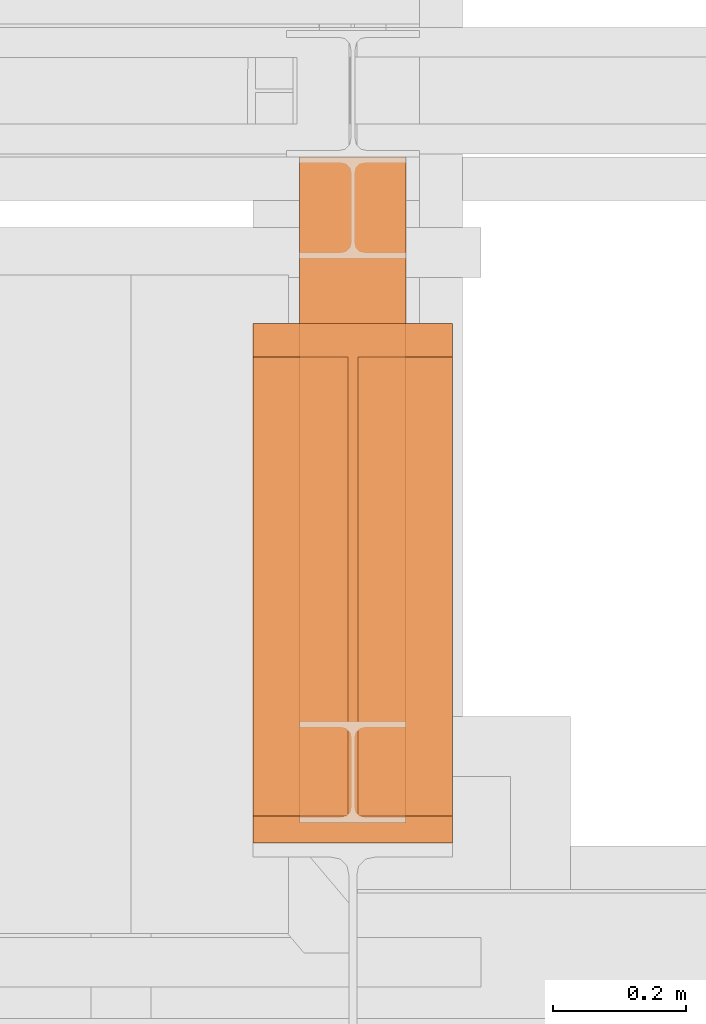
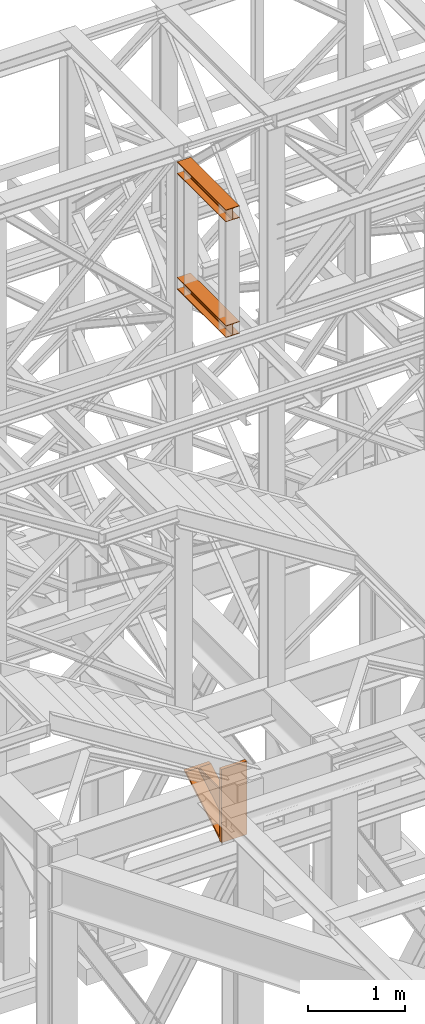
# One storey, part 86 of 208: 3 proxies.
"""IFC2X3 building model written with IfcOpenShell, lengths in millimetres."""

from ifc_helpers import new_model, entity, si_unit, converted_unit, frame, origin, origin_with_axes, place, context, subcontext, project, spatial, faceted_brep, element, save


model = new_model("IFC2X3")

# Units and contexts
model_context = context("Model", 3, precision=1e-05, world=origin())
plan_context = context("Plan", 3, precision=1e-05, world=origin())
body_context = subcontext(model_context, "Body", "Model", "MODEL_VIEW")
ifc_project = project(units=[si_unit("LENGTHUNIT", "METRE", prefix="MILLI"), converted_unit("PLANEANGLEUNIT", "DEGREE", entity("IfcPlaneAngleMeasure", 0.0174532925199433), si_unit("PLANEANGLEUNIT", "RADIAN"), dimensions=[0, 0, 0, 0, 0, 0, 0]), si_unit("AREAUNIT", "SQUARE_METRE"), si_unit("VOLUMEUNIT", "CUBIC_METRE")], contexts=[model_context, plan_context])

# Building, storey
building_placement = place(None, origin())
building = spatial("IfcBuilding", under=ifc_project, at=building_placement, CompositionType="COMPLEX")
storey_placement = place(building_placement, origin_with_axes())
storey = spatial("IfcBuildingStorey", under=building, at=storey_placement, Name="Geschoss", CompositionType="ELEMENT")

# Proxies
proxy_1_placement = place(storey_placement, frame((-1256.745037431798, -17092.57439173937, 4367.230005364415), z_axis=(0.0, 0.0, 1.0), x_axis=(1.0, 0.0, 0.0)))
element("IfcBuildingElementProxy", 1, at=proxy_1_placement, inside=storey, context=body_context, shape_type="Brep", body=[
    faceted_brep([(0.009999999999990905, 40.0099999999984, 18.61000000000058), (300.01, 40.0099999999984, 18.61000000000058), (300.01, 779.8719999999994, 445.7700000000004), (0.009999999999990905, 779.8719999999994, 445.7700000000004), (0.009999999999990905, 779.8719999999994, 445.7700000000004), (300.01, 779.8719999999994, 445.7700000000004), (300.01, 729.8159999999989, 445.7710000000006), (157.51, 729.8159999999989, 445.7710000000006), (157.51, 40.0099999999984, 445.7700000000004), (142.51, 40.0099999999984, 445.7700000000004), (142.51, 729.8159999999989, 445.7710000000006), (0.009999999999990905, 729.8159999999989, 445.7710000000006), (0.009999999999990905, 729.8159999999989, 445.7710000000006), (142.51, 729.8159999999989, 445.7710000000006), (142.51, 40.0099999999984, 47.51000000000022), (0.009999999999990905, 40.0099999999984, 47.51000000000022), (157.51, 40.0099999999984, 47.51000000000022), (157.51, 729.8159999999989, 445.7710000000006), (300.01, 729.8159999999989, 445.7710000000006), (300.01, 40.0099999999984, 47.51000000000022), (0.009999999999990905, 40.0099999999984, 18.61000000000058), (0.009999999999990905, 779.8719999999994, 445.7700000000004), (0.009999999999990905, 729.8159999999989, 445.7710000000006), (0.009999999999990905, 40.0099999999984, 47.51000000000022), (0.009999999999990905, 40.0099999999984, 917.7700000000004), (0.009999999999990905, 0.00999999999839929, 917.7700000000004), (0.009999999999990905, 0.00999999999839929, 0.01000000000021828), (0.009999999999990905, 40.0099999999984, 0.01000000000021828), (300.01, 0.00999999999839929, 917.7700000000004), (300.01, 40.0099999999984, 917.7700000000004), (300.01, 40.0099999999984, 47.51000000000022), (300.01, 729.8159999999989, 445.7710000000006), (300.01, 779.8719999999994, 445.7700000000004), (300.01, 40.0099999999984, 18.61000000000058), (300.01, 40.0099999999984, 0.01000000000021828), (300.01, 0.00999999999839929, 0.01000000000021828), (300.01, 0.00999999999839929, 917.7700000000004), (0.009999999999990905, 0.00999999999839929, 917.7700000000004), (0.009999999999990905, 40.0099999999984, 917.7700000000004), (300.01, 40.0099999999984, 917.7700000000004), (300.01, 40.0099999999984, 917.7700000000004), (0.009999999999990905, 40.0099999999984, 917.7700000000004), (0.009999999999990905, 40.0099999999984, 47.51000000000022), (142.51, 40.0099999999984, 47.51000000000022), (142.51, 40.0099999999984, 445.7700000000004), (157.51, 40.0099999999984, 445.7700000000004), (157.51, 40.0099999999984, 47.51000000000022), (300.01, 40.0099999999984, 47.51000000000022), (300.01, 40.0099999999984, 18.61000000000058), (0.009999999999990905, 40.0099999999984, 18.61000000000058), (0.009999999999990905, 40.0099999999984, 0.01000000000021828), (300.01, 40.0099999999984, 0.01000000000021828), (300.01, 40.0099999999984, 0.01000000000021828), (0.009999999999990905, 40.0099999999984, 0.01000000000021828), (0.009999999999990905, 0.00999999999839929, 0.01000000000021828), (300.01, 0.00999999999839929, 0.01000000000021828), (300.01, 0.00999999999839929, 0.01000000000021828), (0.009999999999990905, 0.00999999999839929, 0.01000000000021828), (0.009999999999990905, 0.00999999999839929, 917.7700000000004), (300.01, 0.00999999999839929, 917.7700000000004), (142.51, 40.0099999999984, 47.51000000000022), (142.51, 729.8159999999989, 445.7710000000006), (142.51, 40.0099999999984, 445.7700000000004), (157.51, 40.0099999999984, 47.51000000000022), (157.51, 40.0099999999984, 445.7700000000004), (157.51, 729.8159999999989, 445.7710000000006)], [[[0, 1, 2, 3]], [[4, 5, 6, 7, 8, 9, 10, 11]], [[12, 13, 14, 15]], [[16, 17, 18, 19]], [[20, 21, 22, 23, 24, 25, 26, 27]], [[28, 29, 30, 31, 32, 33, 34, 35]], [[36, 37, 38, 39]], [[40, 41, 42, 43, 44, 45, 46, 47]], [[48, 49, 50, 51]], [[52, 53, 54, 55]], [[56, 57, 58, 59]], [[60, 61, 62]], [[63, 64, 65]]], orient=[[False], [False], [False], [False], [False], [False], [False], [False], [False], [False], [False], [False], [False]]),
])
proxy_2_placement = place(storey_placement, frame((-1186.582758501437, -17062.574391808, 12097.99004868023), z_axis=(0.0, 0.0, 1.0), x_axis=(1.0, 0.0, 0.0)))
element("IfcBuildingElementProxy", 2, at=proxy_2_placement, inside=storey, context=body_context, shape_type="Brep", body=[
    faceted_brep([(160.0100113248825, 0.00999999999839929, 0.01000000000021828), (0.009999999999990905, 0.00999999999839929, 0.01000000000021828), (0.009999999999990905, 0.00999999999839929, 9.010003337860326), (62.01000457465648, 0.00999999999839929, 9.010003337860326), (69.77318079978227, 0.00999999999839929, 10.5637921190264), (75.45621545821427, 0.00999999999839929, 16.24682677745841), (77.01000563636421, 0.00999999999839929, 24.01000020861648), (77.01000563636421, 0.00999999999839929, 128.010006079674), (75.45621545821427, 0.00999999999839929, 135.7731832361224), (69.77318079978227, 0.00999999999839929, 141.4562178945544), (62.01000457465648, 0.00999999999839929, 143.0100066757204), (0.009999999999990905, 0.00999999999839929, 143.0100066757204), (0.009999999999990905, 0.00999999999839929, 152.0100100135805), (160.0100113248825, 0.00999999999839929, 152.0100100135805), (160.0100113248825, 0.00999999999839929, 143.0100066757204), (98.01000675022601, 0.00999999999839929, 143.0100066757204), (90.24683052510022, 0.00999999999839929, 141.4562178945544), (84.56379586666822, 0.00999999999839929, 135.7731832361224), (83.01000568851828, 0.00999999999839929, 128.010006079674), (83.01000568851828, 0.00999999999839929, 24.01000020861648), (84.56379586666822, 0.00999999999839929, 16.24682677745841), (90.24683052510022, 0.00999999999839929, 10.5637921190264), (98.01000675022601, 0.00999999999839929, 9.010003337860326), (160.0100113248825, 0.00999999999839929, 9.010003337860326), (0.009999999999990905, 0.00999999999839929, 0.01000000000021828), (160.0100113248825, 0.00999999999839929, 0.01000000000021828), (160.0100113248789, 1000.009999999997, 0.01000000000021828), (0.009999999999990905, 1000.009999999997, 0.01000000000021828), (0.009999999999990905, 0.00999999999839929, 9.010003337860326), (0.009999999999990905, 0.00999999999839929, 0.01000000000021828), (0.009999999999990905, 1000.009999999997, 0.01000000000021828), (0.009999999999990905, 1000.009999999997, 9.010003337860326), (62.01000457465648, 0.00999999999839929, 9.010003337860326), (0.009999999999990905, 0.00999999999839929, 9.010003337860326), (0.009999999999990905, 1000.009999999997, 9.010003337860326), (62.01000457465648, 1000.009999999997, 9.010003337860326), (69.77318079978227, 0.00999999999839929, 10.5637921190264), (62.01000457465648, 0.00999999999839929, 9.010003337860326), (62.01000457465648, 1000.009999999997, 9.010003337860326), (69.77318079977863, 1000.009999999997, 10.5637921190264), (75.45621545821427, 0.00999999999839929, 16.24682677745841), (69.77318079978227, 0.00999999999839929, 10.5637921190264), (69.77318079977863, 1000.009999999997, 10.5637921190264), (75.45621545821064, 1000.009999999997, 16.24682677745841), (77.01000563636421, 0.00999999999839929, 24.01000020861648), (75.45621545821427, 0.00999999999839929, 16.24682677745841), (75.45621545821064, 1000.009999999997, 16.24682677745841), (77.01000563636057, 1000.009999999997, 24.01000020861648), (77.01000563636421, 0.00999999999839929, 128.010006079674), (77.01000563636421, 0.00999999999839929, 24.01000020861648), (77.01000563636057, 1000.009999999997, 24.01000020861648), (77.01000563636057, 1000.009999999997, 128.010006079674), (75.45621545821427, 0.00999999999839929, 135.7731832361224), (77.01000563636421, 0.00999999999839929, 128.010006079674), (77.01000563636057, 1000.009999999997, 128.010006079674), (75.45621545821064, 1000.009999999997, 135.7731832361224), (69.77318079978227, 0.00999999999839929, 141.4562178945544), (75.45621545821427, 0.00999999999839929, 135.7731832361224), (75.45621545821064, 1000.009999999997, 135.7731832361224), (69.77318079977863, 1000.009999999997, 141.4562178945544), (62.01000457465648, 0.00999999999839929, 143.0100066757204), (69.77318079978227, 0.00999999999839929, 141.4562178945544), (69.77318079977863, 1000.009999999997, 141.4562178945544), (62.01000457465284, 1000.009999999997, 143.0100066757204), (0.009999999999990905, 0.00999999999839929, 143.0100066757204), (62.01000457465648, 0.00999999999839929, 143.0100066757204), (62.01000457465284, 1000.009999999997, 143.0100066757204), (0.009999999999990905, 1000.009999999997, 143.0100066757204), (0.009999999999990905, 0.00999999999839929, 152.0100100135805), (0.009999999999990905, 0.00999999999839929, 143.0100066757204), (0.009999999999990905, 1000.009999999997, 143.0100066757204), (0.009999999999990905, 1000.009999999997, 152.0100100135805), (160.0100113248825, 0.00999999999839929, 152.0100100135805), (0.009999999999990905, 0.00999999999839929, 152.0100100135805), (0.009999999999990905, 1000.009999999997, 152.0100100135805), (160.0100113248825, 1000.009999999997, 152.0100100135842), (160.0100113248825, 0.00999999999839929, 143.0100066757204), (160.0100113248825, 0.00999999999839929, 152.0100100135805), (160.0100113248825, 1000.009999999997, 152.0100100135842), (160.0100113248825, 1000.009999999997, 143.0100066757204), (98.01000675022601, 0.00999999999839929, 143.0100066757204), (160.0100113248825, 0.00999999999839929, 143.0100066757204), (160.0100113248825, 1000.009999999997, 143.0100066757204), (98.01000675022237, 1000.009999999997, 143.0100066757204), (90.24683052510022, 0.00999999999839929, 141.4562178945544), (98.01000675022601, 0.00999999999839929, 143.0100066757204), (98.01000675022237, 1000.009999999997, 143.0100066757204), (90.24683052509658, 1000.009999999997, 141.4562178945544), (84.56379586666822, 0.00999999999839929, 135.7731832361224), (90.24683052510022, 0.00999999999839929, 141.4562178945544), (90.24683052509658, 1000.009999999997, 141.4562178945544), (84.56379586666458, 1000.009999999997, 135.773183236126), (83.01000568851828, 0.00999999999839929, 128.010006079674), (84.56379586666822, 0.00999999999839929, 135.7731832361224), (84.56379586666458, 1000.009999999997, 135.773183236126), (83.01000568851464, 1000.009999999997, 128.0100060796776), (83.01000568851828, 0.00999999999839929, 24.01000020861648), (83.01000568851828, 0.00999999999839929, 128.010006079674), (83.01000568851464, 1000.009999999997, 128.0100060796776), (83.01000568851464, 1000.009999999997, 24.01000020861648), (84.56379586666822, 0.00999999999839929, 16.24682677745841), (83.01000568851828, 0.00999999999839929, 24.01000020861648), (83.01000568851464, 1000.009999999997, 24.01000020861648), (84.56379586666458, 1000.009999999997, 16.24682677745841), (90.24683052510022, 0.00999999999839929, 10.5637921190264), (84.56379586666822, 0.00999999999839929, 16.24682677745841), (84.56379586666458, 1000.009999999997, 16.24682677745841), (90.24683052509658, 1000.009999999997, 10.5637921190264), (98.01000675022601, 0.00999999999839929, 9.010003337860326), (90.24683052510022, 0.00999999999839929, 10.5637921190264), (90.24683052509658, 1000.009999999997, 10.5637921190264), (98.01000675022237, 1000.009999999997, 9.010003337860326), (160.0100113248825, 0.00999999999839929, 9.010003337860326), (98.01000675022601, 0.00999999999839929, 9.010003337860326), (98.01000675022237, 1000.009999999997, 9.010003337860326), (160.0100113248825, 1000.009999999997, 9.010003337860326), (160.0100113248825, 0.00999999999839929, 0.01000000000021828), (160.0100113248825, 0.00999999999839929, 9.010003337860326), (160.0100113248825, 1000.009999999997, 9.010003337860326), (160.0100113248789, 1000.009999999997, 0.01000000000021828), (160.0100113248789, 1000.009999999997, 0.01000000000021828), (160.0100113248825, 1000.009999999997, 9.010003337860326), (98.01000675022237, 1000.009999999997, 9.010003337860326), (90.24683052509658, 1000.009999999997, 10.5637921190264), (84.56379586666458, 1000.009999999997, 16.24682677745841), (83.01000568851464, 1000.009999999997, 24.01000020861648), (83.01000568851464, 1000.009999999997, 128.0100060796776), (84.56379586666458, 1000.009999999997, 135.773183236126), (90.24683052509658, 1000.009999999997, 141.4562178945544), (98.01000675022237, 1000.009999999997, 143.0100066757204), (160.0100113248825, 1000.009999999997, 143.0100066757204), (160.0100113248825, 1000.009999999997, 152.0100100135842), (0.009999999999990905, 1000.009999999997, 152.0100100135805), (0.009999999999990905, 1000.009999999997, 143.0100066757204), (62.01000457465284, 1000.009999999997, 143.0100066757204), (69.77318079977863, 1000.009999999997, 141.4562178945544), (75.45621545821064, 1000.009999999997, 135.7731832361224), (77.01000563636057, 1000.009999999997, 128.010006079674), (77.01000563636057, 1000.009999999997, 24.01000020861648), (75.45621545821064, 1000.009999999997, 16.24682677745841), (69.77318079977863, 1000.009999999997, 10.5637921190264), (62.01000457465648, 1000.009999999997, 9.010003337860326), (0.009999999999990905, 1000.009999999997, 9.010003337860326), (0.009999999999990905, 1000.009999999997, 0.01000000000021828)], [[[0, 1, 2, 3, 4, 5, 6, 7, 8, 9, 10, 11, 12, 13, 14, 15, 16, 17, 18, 19, 20, 21, 22, 23]], [[24, 25, 26, 27]], [[28, 29, 30, 31]], [[32, 33, 34, 35]], [[36, 37, 38, 39]], [[40, 41, 42, 43]], [[44, 45, 46, 47]], [[48, 49, 50, 51]], [[52, 53, 54, 55]], [[56, 57, 58, 59]], [[60, 61, 62, 63]], [[64, 65, 66, 67]], [[68, 69, 70, 71]], [[72, 73, 74, 75]], [[76, 77, 78, 79]], [[80, 81, 82, 83]], [[84, 85, 86, 87]], [[88, 89, 90, 91]], [[92, 93, 94, 95]], [[96, 97, 98, 99]], [[100, 101, 102, 103]], [[104, 105, 106, 107]], [[108, 109, 110, 111]], [[112, 113, 114, 115]], [[116, 117, 118, 119]], [[120, 121, 122, 123, 124, 125, 126, 127, 128, 129, 130, 131, 132, 133, 134, 135, 136, 137, 138, 139, 140, 141, 142, 143]]], orient=[[False], [False], [False], [False], [False], [False], [False], [False], [False], [False], [False], [False], [False], [False], [False], [False], [False], [False], [False], [False], [False], [False], [False], [False], [False], [False]]),
])
proxy_3_placement = place(storey_placement, frame((-1186.582758501437, -17062.574391808, 10649.99005869381), z_axis=(0.0, 0.0, 1.0), x_axis=(1.0, 0.0, 0.0)))
element("IfcBuildingElementProxy", 3, at=proxy_3_placement, inside=storey, context=body_context, shape_type="Brep", body=[
    faceted_brep([(160.0100113248825, 0.00999999999839929, 0.01000000000021828), (0.009999999999990905, 0.00999999999839929, 0.01000000000021828), (0.009999999999990905, 0.00999999999839929, 9.010003337860326), (62.01000457465648, 0.00999999999839929, 9.010003337860326), (69.77318079978227, 0.00999999999839929, 10.5637921190264), (75.45621545821427, 0.00999999999839929, 16.24682677745841), (77.01000563636421, 0.00999999999839929, 24.01000020861648), (77.01000563636421, 0.00999999999839929, 128.010006079674), (75.45621545821427, 0.00999999999839929, 135.7731832361224), (69.77318079978227, 0.00999999999839929, 141.4562178945544), (62.01000457465648, 0.00999999999839929, 143.0100066757204), (0.009999999999990905, 0.00999999999839929, 143.0100066757204), (0.009999999999990905, 0.00999999999839929, 152.0100100135805), (160.0100113248825, 0.00999999999839929, 152.0100100135805), (160.0100113248825, 0.00999999999839929, 143.0100066757204), (98.01000675022601, 0.00999999999839929, 143.0100066757204), (90.24683052510022, 0.00999999999839929, 141.4562178945544), (84.56379586666822, 0.00999999999839929, 135.7731832361224), (83.01000568851828, 0.00999999999839929, 128.010006079674), (83.01000568851828, 0.00999999999839929, 24.01000020861648), (84.56379586666822, 0.00999999999839929, 16.24682677745841), (90.24683052510022, 0.00999999999839929, 10.5637921190264), (98.01000675022601, 0.00999999999839929, 9.010003337860326), (160.0100113248825, 0.00999999999839929, 9.010003337860326), (0.009999999999990905, 0.00999999999839929, 0.01000000000021828), (160.0100113248825, 0.00999999999839929, 0.01000000000021828), (160.0100113248789, 1000.009999999997, 0.01000000000021828), (0.009999999999990905, 1000.009999999997, 0.01000000000021828), (0.009999999999990905, 0.00999999999839929, 9.010003337860326), (0.009999999999990905, 0.00999999999839929, 0.01000000000021828), (0.009999999999990905, 1000.009999999997, 0.01000000000021828), (0.009999999999990905, 1000.009999999997, 9.010003337860326), (62.01000457465648, 0.00999999999839929, 9.010003337860326), (0.009999999999990905, 0.00999999999839929, 9.010003337860326), (0.009999999999990905, 1000.009999999997, 9.010003337860326), (62.01000457465648, 1000.009999999997, 9.010003337860326), (69.77318079978227, 0.00999999999839929, 10.5637921190264), (62.01000457465648, 0.00999999999839929, 9.010003337860326), (62.01000457465648, 1000.009999999997, 9.010003337860326), (69.77318079977863, 1000.009999999997, 10.5637921190264), (75.45621545821427, 0.00999999999839929, 16.24682677745841), (69.77318079978227, 0.00999999999839929, 10.5637921190264), (69.77318079977863, 1000.009999999997, 10.5637921190264), (75.45621545821064, 1000.009999999997, 16.24682677745841), (77.01000563636421, 0.00999999999839929, 24.01000020861648), (75.45621545821427, 0.00999999999839929, 16.24682677745841), (75.45621545821064, 1000.009999999997, 16.24682677745841), (77.01000563636057, 1000.009999999997, 24.01000020861648), (77.01000563636421, 0.00999999999839929, 128.010006079674), (77.01000563636421, 0.00999999999839929, 24.01000020861648), (77.01000563636057, 1000.009999999997, 24.01000020861648), (77.01000563636057, 1000.009999999997, 128.010006079674), (75.45621545821427, 0.00999999999839929, 135.7731832361224), (77.01000563636421, 0.00999999999839929, 128.010006079674), (77.01000563636057, 1000.009999999997, 128.010006079674), (75.45621545821064, 1000.009999999997, 135.7731832361224), (69.77318079978227, 0.00999999999839929, 141.4562178945544), (75.45621545821427, 0.00999999999839929, 135.7731832361224), (75.45621545821064, 1000.009999999997, 135.7731832361224), (69.77318079977863, 1000.009999999997, 141.4562178945544), (62.01000457465648, 0.00999999999839929, 143.0100066757204), (69.77318079978227, 0.00999999999839929, 141.4562178945544), (69.77318079977863, 1000.009999999997, 141.4562178945544), (62.01000457465284, 1000.009999999997, 143.0100066757204), (0.009999999999990905, 0.00999999999839929, 143.0100066757204), (62.01000457465648, 0.00999999999839929, 143.0100066757204), (62.01000457465284, 1000.009999999997, 143.0100066757204), (0.009999999999990905, 1000.009999999997, 143.0100066757204), (0.009999999999990905, 0.00999999999839929, 152.0100100135805), (0.009999999999990905, 0.00999999999839929, 143.0100066757204), (0.009999999999990905, 1000.009999999997, 143.0100066757204), (0.009999999999990905, 1000.009999999997, 152.0100100135805), (160.0100113248825, 0.00999999999839929, 152.0100100135805), (0.009999999999990905, 0.00999999999839929, 152.0100100135805), (0.009999999999990905, 1000.009999999997, 152.0100100135805), (160.0100113248825, 1000.009999999997, 152.0100100135842), (160.0100113248825, 0.00999999999839929, 143.0100066757204), (160.0100113248825, 0.00999999999839929, 152.0100100135805), (160.0100113248825, 1000.009999999997, 152.0100100135842), (160.0100113248825, 1000.009999999997, 143.0100066757204), (98.01000675022601, 0.00999999999839929, 143.0100066757204), (160.0100113248825, 0.00999999999839929, 143.0100066757204), (160.0100113248825, 1000.009999999997, 143.0100066757204), (98.01000675022237, 1000.009999999997, 143.0100066757204), (90.24683052510022, 0.00999999999839929, 141.4562178945544), (98.01000675022601, 0.00999999999839929, 143.0100066757204), (98.01000675022237, 1000.009999999997, 143.0100066757204), (90.24683052509658, 1000.009999999997, 141.4562178945544), (84.56379586666822, 0.00999999999839929, 135.7731832361224), (90.24683052510022, 0.00999999999839929, 141.4562178945544), (90.24683052509658, 1000.009999999997, 141.4562178945544), (84.56379586666458, 1000.009999999997, 135.773183236126), (83.01000568851828, 0.00999999999839929, 128.010006079674), (84.56379586666822, 0.00999999999839929, 135.7731832361224), (84.56379586666458, 1000.009999999997, 135.773183236126), (83.01000568851464, 1000.009999999997, 128.0100060796776), (83.01000568851828, 0.00999999999839929, 24.01000020861648), (83.01000568851828, 0.00999999999839929, 128.010006079674), (83.01000568851464, 1000.009999999997, 128.0100060796776), (83.01000568851464, 1000.009999999997, 24.01000020861648), (84.56379586666822, 0.00999999999839929, 16.24682677745841), (83.01000568851828, 0.00999999999839929, 24.01000020861648), (83.01000568851464, 1000.009999999997, 24.01000020861648), (84.56379586666458, 1000.009999999997, 16.24682677745841), (90.24683052510022, 0.00999999999839929, 10.5637921190264), (84.56379586666822, 0.00999999999839929, 16.24682677745841), (84.56379586666458, 1000.009999999997, 16.24682677745841), (90.24683052509658, 1000.009999999997, 10.5637921190264), (98.01000675022601, 0.00999999999839929, 9.010003337860326), (90.24683052510022, 0.00999999999839929, 10.5637921190264), (90.24683052509658, 1000.009999999997, 10.5637921190264), (98.01000675022237, 1000.009999999997, 9.010003337860326), (160.0100113248825, 0.00999999999839929, 9.010003337860326), (98.01000675022601, 0.00999999999839929, 9.010003337860326), (98.01000675022237, 1000.009999999997, 9.010003337860326), (160.0100113248825, 1000.009999999997, 9.010003337860326), (160.0100113248825, 0.00999999999839929, 0.01000000000021828), (160.0100113248825, 0.00999999999839929, 9.010003337860326), (160.0100113248825, 1000.009999999997, 9.010003337860326), (160.0100113248789, 1000.009999999997, 0.01000000000021828), (160.0100113248789, 1000.009999999997, 0.01000000000021828), (160.0100113248825, 1000.009999999997, 9.010003337860326), (98.01000675022237, 1000.009999999997, 9.010003337860326), (90.24683052509658, 1000.009999999997, 10.5637921190264), (84.56379586666458, 1000.009999999997, 16.24682677745841), (83.01000568851464, 1000.009999999997, 24.01000020861648), (83.01000568851464, 1000.009999999997, 128.0100060796776), (84.56379586666458, 1000.009999999997, 135.773183236126), (90.24683052509658, 1000.009999999997, 141.4562178945544), (98.01000675022237, 1000.009999999997, 143.0100066757204), (160.0100113248825, 1000.009999999997, 143.0100066757204), (160.0100113248825, 1000.009999999997, 152.0100100135842), (0.009999999999990905, 1000.009999999997, 152.0100100135805), (0.009999999999990905, 1000.009999999997, 143.0100066757204), (62.01000457465284, 1000.009999999997, 143.0100066757204), (69.77318079977863, 1000.009999999997, 141.4562178945544), (75.45621545821064, 1000.009999999997, 135.7731832361224), (77.01000563636057, 1000.009999999997, 128.010006079674), (77.01000563636057, 1000.009999999997, 24.01000020861648), (75.45621545821064, 1000.009999999997, 16.24682677745841), (69.77318079977863, 1000.009999999997, 10.5637921190264), (62.01000457465648, 1000.009999999997, 9.010003337860326), (0.009999999999990905, 1000.009999999997, 9.010003337860326), (0.009999999999990905, 1000.009999999997, 0.01000000000021828)], [[[0, 1, 2, 3, 4, 5, 6, 7, 8, 9, 10, 11, 12, 13, 14, 15, 16, 17, 18, 19, 20, 21, 22, 23]], [[24, 25, 26, 27]], [[28, 29, 30, 31]], [[32, 33, 34, 35]], [[36, 37, 38, 39]], [[40, 41, 42, 43]], [[44, 45, 46, 47]], [[48, 49, 50, 51]], [[52, 53, 54, 55]], [[56, 57, 58, 59]], [[60, 61, 62, 63]], [[64, 65, 66, 67]], [[68, 69, 70, 71]], [[72, 73, 74, 75]], [[76, 77, 78, 79]], [[80, 81, 82, 83]], [[84, 85, 86, 87]], [[88, 89, 90, 91]], [[92, 93, 94, 95]], [[96, 97, 98, 99]], [[100, 101, 102, 103]], [[104, 105, 106, 107]], [[108, 109, 110, 111]], [[112, 113, 114, 115]], [[116, 117, 118, 119]], [[120, 121, 122, 123, 124, 125, 126, 127, 128, 129, 130, 131, 132, 133, 134, 135, 136, 137, 138, 139, 140, 141, 142, 143]]], orient=[[False], [False], [False], [False], [False], [False], [False], [False], [False], [False], [False], [False], [False], [False], [False], [False], [False], [False], [False], [False], [False], [False], [False], [False], [False], [False]]),
])

save(model, "model.ifc")
